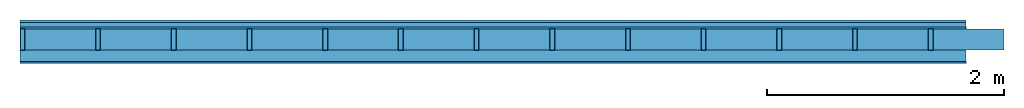
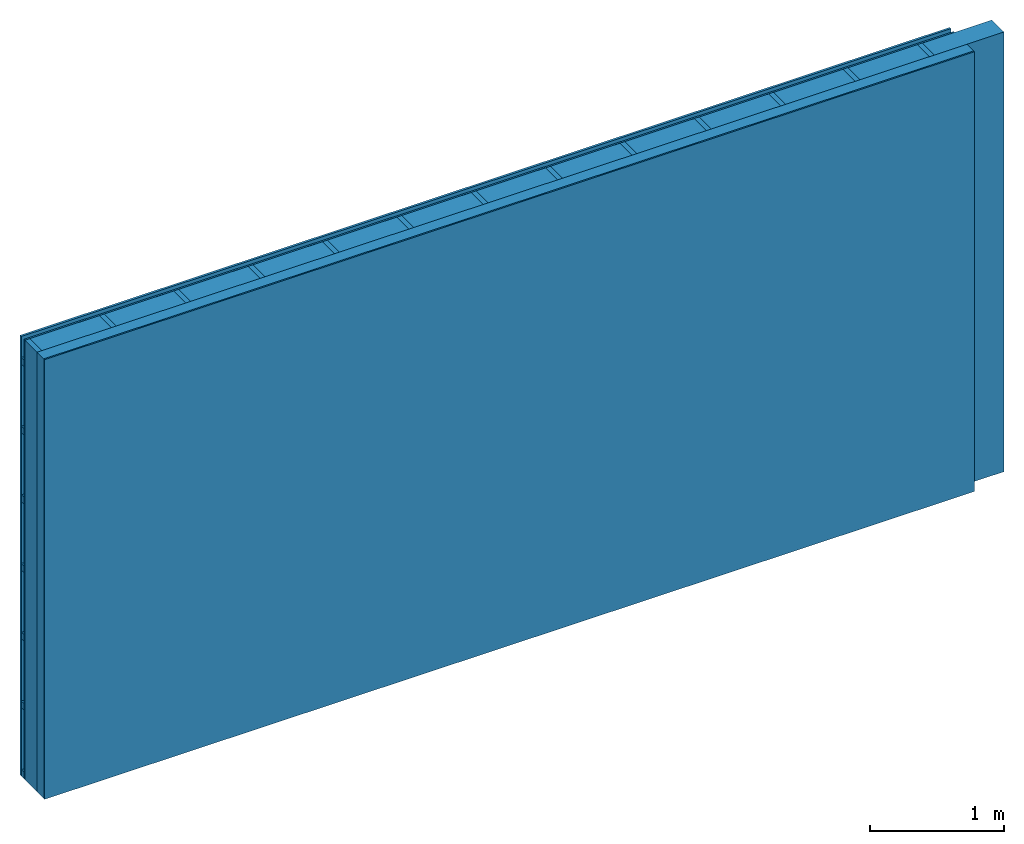
# One storey: 4 plates, 3 members, 1 element without a shape of its own.
"""IFC4 building model written with IfcOpenShell, lengths in metres."""

import ifcopenshell
import ifcopenshell.guid

model = None  # the IFC model being written
_history = None  # IfcOwnerHistory: only IFC2X3 demands one
_inside = {}  # id of a spatial element -> (the spatial element, [elements in it])
_under = {}  # id of a project, library or spatial element -> (it, [spatial elements below it])
_declared = {}  # id of a project -> (the project, [libraries it declares])
_typed = {}  # id of a type object -> (the type object, [elements of that type])
_made_of = {}  # id of a material, layer set ... -> (it, [elements and type objects made of it])


def new_model(schema):
    """Start an empty IFC model of exactly this schema.

    Asked for "IFC4X3", IfcOpenShell would pick the latest addendum, in which some entities
    have other attributes; the version numbers below select the first issue.
    IFC2X3 requires an IfcOwnerHistory on every rooted entity: one is made here for all.
    """
    global model, _history
    if schema == "IFC4X3":
        model = ifcopenshell.file(schema_version=(4, 3, 0, 0))
    else:
        model = ifcopenshell.file(schema=schema)
    _inside.clear()
    _under.clear()
    _declared.clear()
    _typed.clear()
    _made_of.clear()
    _history = None
    if model.schema == "IFC2X3":
        org = make("IfcOrganization", Name="unknown")
        user = make(
            "IfcPersonAndOrganization",
            ThePerson=make("IfcPerson", FamilyName="unknown"),
            TheOrganization=org,
        )
        app = make(
            "IfcApplication",
            ApplicationDeveloper=org,
            Version="unknown",
            ApplicationFullName="unknown",
            ApplicationIdentifier="unknown",
        )
        _history = make(
            "IfcOwnerHistory",
            OwningUser=user,
            OwningApplication=app,
            ChangeAction="ADDED",
            CreationDate=0,
        )
    return model


def make(cls, **values):
    """One entity of the class cls with the attributes given. An attribute that is None is left unset."""
    return model.create_entity(
        cls, **{name: value for name, value in values.items() if value is not None}
    )


def rooted(cls, **values):
    """An entity with a GlobalId (a new one), such as an element, a storey or a relation."""
    return make(cls, GlobalId=ifcopenshell.guid.new(), OwnerHistory=_history, **values)


def si_unit(unit_type, name, prefix=None):
    """IfcSIUnit, for example si_unit("LENGTHUNIT", "METRE", prefix="MILLI")."""
    return make("IfcSIUnit", UnitType=unit_type, Prefix=prefix, Name=name)


def derived_unit(unit_type, elements):
    """IfcDerivedUnit: a product of units, each with its exponent."""
    return make(
        "IfcDerivedUnit",
        Elements=[
            make("IfcDerivedUnitElement", Unit=unit, Exponent=power)
            for unit, power in elements
        ],
        UnitType=unit_type,
    )


def assignment(units):
    """IfcUnitAssignment: the units of a project."""
    return None if units is None else make("IfcUnitAssignment", Units=units)


def point(xyz):
    """IfcCartesianPoint."""
    return None if xyz is None else make("IfcCartesianPoint", Coordinates=xyz)


def direction(xyz):
    """IfcDirection."""
    return None if xyz is None else make("IfcDirection", DirectionRatios=xyz)


def frame(location, z_axis=None, x_axis=None):
    """IfcAxis2Placement3D, a coordinate frame: its origin and axes. An axis left out is left unset."""
    return make(
        "IfcAxis2Placement3D",
        Location=point(location),
        Axis=direction(z_axis),
        RefDirection=direction(x_axis),
    )


def frame_2d(location, x_axis=None):
    """IfcAxis2Placement2D, a coordinate frame in the plane: its origin and x axis."""
    return make(
        "IfcAxis2Placement2D", Location=point(location), RefDirection=direction(x_axis)
    )


def origin():
    """The frame at (0, 0, 0) with its axes left unset."""
    return frame((0.0, 0.0, 0.0))


def origin_with_axes():
    """The frame at (0, 0, 0) with the z axis (0, 0, 1) and the x axis (1, 0, 0) written out."""
    return frame((0.0, 0.0, 0.0), z_axis=(0.0, 0.0, 1.0), x_axis=(1.0, 0.0, 0.0))


def place(relative_to, where):
    """IfcLocalPlacement: puts the frame where relative to a parent placement (None: the world)."""
    return make(
        "IfcLocalPlacement", PlacementRelTo=relative_to, RelativePlacement=where
    )


def context(
    kind, dimensions, precision=None, world=None, true_north=None, identifier=None
):
    """IfcGeometricRepresentationContext, for example the 3D "Model" context."""
    return make(
        "IfcGeometricRepresentationContext",
        ContextIdentifier=identifier,
        ContextType=kind,
        CoordinateSpaceDimension=dimensions,
        Precision=precision,
        WorldCoordinateSystem=world,
        TrueNorth=true_north,
    )


def project(units=None, contexts=None):
    """IfcProject with its units and contexts."""
    return rooted(
        "IfcProject",
        Name="project",
        RepresentationContexts=contexts,
        UnitsInContext=assignment(units),
    )


def spatial(cls, under=None, at=None, **own):
    """A site, building, storey or space (cls), placed at a placement, below another one or the project."""
    s = rooted(cls, ObjectPlacement=at, **own)
    if under is not None:
        _under.setdefault(under.id(), (under, []))[1].append(s)
    return s


def profile(cls, at=None, kind="AREA", **sizes):
    """A parametric profile (cls). Its sizes go by their IFC names, for example OverallWidth=200.0."""
    return make(cls, ProfileType=kind, Position=at, **sizes)


def rectangle(**sizes):
    """IfcRectangleProfileDef."""
    return profile("IfcRectangleProfileDef", **sizes)


def extrude(swept, where, along, depth):
    """IfcExtrudedAreaSolid: the profile swept, set in the frame where, extruded along a direction by depth."""
    return make(
        "IfcExtrudedAreaSolid",
        SweptArea=swept,
        Position=where,
        ExtrudedDirection=direction(along),
        Depth=depth,
    )


def shape(context_of_items, identifier, shape_type, items):
    """IfcShapeRepresentation: the items that make up one representation, for example the "Body"."""
    return make(
        "IfcShapeRepresentation",
        ContextOfItems=context_of_items,
        RepresentationIdentifier=identifier,
        RepresentationType=shape_type,
        Items=items,
    )


def material(Name=None, Category=None):
    """IfcMaterial."""
    return make("IfcMaterial", Name=Name, Category=Category)


def layer(
    of_material, thickness, ventilated=None, Name=None, Category=None, Priority=None
):
    """IfcMaterialLayer: one layer of a wall or slab, of a material (None: an air gap)."""
    return make(
        "IfcMaterialLayer",
        Material=of_material,
        LayerThickness=thickness,
        IsVentilated=ventilated,
        Name=Name,
        Category=Category,
        Priority=Priority,
    )


def layer_set(layers, Name=None):
    """IfcMaterialLayerSet."""
    return make("IfcMaterialLayerSet", MaterialLayers=layers, LayerSetName=Name)


def made_of(thing, what):
    """Note that an element or type object is made of a material, layer set ...; save() writes the relation."""
    if what is not None:
        _made_of.setdefault(what.id(), (what, []))[1].append(thing)
    return thing


def type_object(cls, material=None, **own):
    """A type object (cls), such as IfcWallType, which elements share."""
    return made_of(rooted(cls, **own), material)


def element(
    cls,
    number,
    at=None,
    inside=None,
    cuts=None,
    type_object=None,
    material=None,
    context=None,
    identifier="Body",
    shape_type=None,
    held_by="IfcProductDefinitionShape",
    body=None,
    shapes=None,
    **own,
):
    """One element of the class cls, such as IfcWall. Its Tag is "e" and its number.

    at: its placement. inside: the storey or other place that contains it. cuts: it is an
    opening in that element (IfcRelVoidsElement). A single representation is given by context,
    identifier, shape_type and body (its items); several are given by shapes. held_by: the class
    of the entity that holds the representations. save() writes the other relations.
    """
    e = rooted(cls, Tag="e%d" % number, ObjectPlacement=at, **own)
    if body is not None:
        shapes = [shape(context, identifier, shape_type, body)]
    if shapes is not None:
        e.Representation = make(held_by, Representations=shapes)
    if inside is not None:
        _inside.setdefault(inside.id(), (inside, []))[1].append(e)
    if cuts is not None:
        rooted(
            "IfcRelVoidsElement", RelatingBuildingElement=cuts, RelatedOpeningElement=e
        )
    if type_object is not None:
        _typed.setdefault(type_object.id(), (type_object, []))[1].append(e)
    return made_of(e, material)


def aggregate(whole, parts):
    """IfcRelAggregates: a whole, such as a stair, and the parts it consists of."""
    return rooted("IfcRelAggregates", RelatingObject=whole, RelatedObjects=parts)


def save(model, path):
    """Write the relations noted so far, then the file.

    IfcRelAggregates (storeys below a building ...), IfcRelContainedInSpatialStructure (elements
    in a storey), IfcRelDefinesByType, IfcRelAssociatesMaterial and IfcRelDeclares: one each for
    every whole, place, type object, material and project.
    """
    for whole, parts in _under.values():
        aggregate(whole, parts)
    for where, things in _inside.values():
        rooted(
            "IfcRelContainedInSpatialStructure",
            RelatedElements=things,
            RelatingStructure=where,
        )
    for kind, things in _typed.values():
        rooted("IfcRelDefinesByType", RelatedObjects=things, RelatingType=kind)
    for what, things in _made_of.values():
        rooted("IfcRelAssociatesMaterial", RelatedObjects=things, RelatingMaterial=what)
    for by, libraries in _declared.values():
        rooted("IfcRelDeclares", RelatingContext=by, RelatedDefinitions=libraries)
    model.write(path)


model = new_model("IFC4")

# Units and contexts
plan_context = context("Plan", 3, precision=1e-05, world=origin(), true_north=direction((0.0, 1.0)))
model_context = context("Model", 3, precision=1e-05, world=origin(), true_north=direction((0.0, 1.0)))
ifc_project = project(units=[si_unit("LENGTHUNIT", "METRE"), derived_unit("SOUNDPRESSUREUNIT", [(si_unit("PRESSUREUNIT", "PASCAL", prefix="MICRO"), 0)]), si_unit("ENERGYUNIT", "JOULE", prefix="MEGA"), si_unit("MASSUNIT", "GRAM", prefix="KILO"), derived_unit("THERMALTRANSMITTANCEUNIT", [(si_unit("POWERUNIT", "WATT"), 1), (si_unit("AREAUNIT", "SQUARE_METRE"), -1), (si_unit("THERMODYNAMICTEMPERATUREUNIT", "KELVIN"), -1)]), derived_unit("AREADENSITYUNIT", [(si_unit("MASSUNIT", "GRAM", prefix="KILO"), 1), (si_unit("AREAUNIT", "SQUARE_METRE"), -1)]), derived_unit("USERDEFINED", [(si_unit("ENERGYUNIT", "JOULE", prefix="MEGA"), 1), (si_unit("AREAUNIT", "SQUARE_METRE"), -1)])], contexts=[plan_context, model_context])

# Site, building, storey
site = spatial("IfcSite", under=ifc_project)
building_placement = place(None, origin())
building = spatial("IfcBuilding", under=site, at=building_placement)
storey_placement = place(building_placement, origin())
storey = spatial("IfcBuildingStorey", under=building, at=storey_placement)

# Wall, members, plates
ifc_material_1 = material(Name="Wood cladding horizontal, closed")
ifc_layer_1 = layer(ifc_material_1, 0.02, Name="Cover 1st layer")
ifc_layer_2 = layer(None, 0.04, Name="Battens / profiles (ventilation)")
ifc_material_2 = material(Category="03.007")
ifc_layer_3 = layer(ifc_material_2, 0.015, Name="outside 1st layer")
ifc_material_3 = material(Name="of the art")
ifc_layer_4 = layer(ifc_material_3, 0.0, Name="Bond")
ifc_layer_5 = layer(None, 0.18, Name="Support")
ifc_layer_6 = layer(ifc_material_3, 0.0, Name="Bond")
ifc_material_4 = material(Name="Solid timber panel")
ifc_layer_7 = layer(ifc_material_4, 0.1, Name="1st layer")
ifc_material_5 = material(Name="Plasterboard type A", Category="03.008")
ifc_layer_8 = layer(ifc_material_5, 0.0125, Name="Covering 1st layer")
ifc_material_6 = material(Name="joints", Category="04.017")
ifc_layer_9 = layer(ifc_material_6, 0.0, Name="Surface")
ifc_layer_set = layer_set([ifc_layer_1, ifc_layer_2, ifc_layer_3, ifc_layer_4, ifc_layer_5, ifc_layer_6, ifc_layer_7, ifc_layer_8, ifc_layer_9])
wall_type = type_object("IfcWallType", Name="D0990", PredefinedType="NOTDEFINED", material=ifc_layer_set)
wall_placement = place(None, frame((0.0, 0.0, 0.0), z_axis=(0.0, -1.0, 0.0), x_axis=(1.0, 0.0, 0.0)))
wall = element("IfcWall", 1, at=wall_placement, inside=storey, type_object=wall_type, material=ifc_layer_set, Name="Wall #1")
ifc_material_7 = material()
member_1_placement = place(wall_placement, origin())
member_1 = element("IfcMember", 2, at=member_1_placement, material=ifc_material_7, Name="Battens / profiles (ventilation)", context=plan_context, shape_type="SweptSolid", body=[
    extrude(rectangle(XDim=0.06, YDim=0.04, at=frame_2d((0.03, 0.02), x_axis=(1.0, 0.0))), frame((0.0, 0.0, 0.02), z_axis=(1.0, 0.0, 0.0), x_axis=(0.0, 1.0, 0.0)), (0.0, 0.0, 1.0), 8.0),
    extrude(rectangle(XDim=0.06, YDim=0.04, at=frame_2d((0.03, 0.02), x_axis=(1.0, 0.0))), frame((0.0, 0.625, 0.02), z_axis=(1.0, 0.0, 0.0), x_axis=(0.0, 1.0, 0.0)), (0.0, 0.0, 1.0), 8.0),
    extrude(rectangle(XDim=0.06, YDim=0.04, at=frame_2d((0.03, 0.02), x_axis=(1.0, 0.0))), frame((0.0, 1.25, 0.02), z_axis=(1.0, 0.0, 0.0), x_axis=(0.0, 1.0, 0.0)), (0.0, 0.0, 1.0), 8.0),
    extrude(rectangle(XDim=0.06, YDim=0.04, at=frame_2d((0.03, 0.02), x_axis=(1.0, 0.0))), frame((0.0, 1.875, 0.02), z_axis=(1.0, 0.0, 0.0), x_axis=(0.0, 1.0, 0.0)), (0.0, 0.0, 1.0), 8.0),
    extrude(rectangle(XDim=0.06, YDim=0.04, at=frame_2d((0.03, 0.02), x_axis=(1.0, 0.0))), frame((0.0, 2.5, 0.02), z_axis=(1.0, 0.0, 0.0), x_axis=(0.0, 1.0, 0.0)), (0.0, 0.0, 1.0), 8.0),
    extrude(rectangle(XDim=0.06, YDim=0.04, at=frame_2d((0.03, 0.02), x_axis=(1.0, 0.0))), frame((0.0, 3.125, 0.02), z_axis=(1.0, 0.0, 0.0), x_axis=(0.0, 1.0, 0.0)), (0.0, 0.0, 1.0), 8.0),
    extrude(rectangle(XDim=0.06, YDim=0.04, at=frame_2d((0.03, 0.02), x_axis=(1.0, 0.0))), frame((0.0, 3.75, 0.02), z_axis=(1.0, 0.0, 0.0), x_axis=(0.0, 1.0, 0.0)), (0.0, 0.0, 1.0), 8.0),
])
ifc_material_8 = material()
member_2_placement = place(wall_placement, origin())
member_2 = element("IfcMember", 3, at=member_2_placement, material=ifc_material_8, Name="Support", context=plan_context, shape_type="SweptSolid", body=[
    extrude(rectangle(XDim=0.04, YDim=0.18, at=frame_2d((0.02, 0.09), x_axis=(1.0, 0.0))), frame((0.0, 4.0, 0.075), z_axis=(0.0, -1.0, 0.0), x_axis=(1.0, 0.0, 0.0)), (0.0, 0.0, 1.0), 4.0),
    extrude(rectangle(XDim=0.04, YDim=0.18, at=frame_2d((0.02, 0.09), x_axis=(1.0, 0.0))), frame((0.64, 4.0, 0.075), z_axis=(0.0, -1.0, 0.0), x_axis=(1.0, 0.0, 0.0)), (0.0, 0.0, 1.0), 4.0),
    extrude(rectangle(XDim=0.04, YDim=0.18, at=frame_2d((0.02, 0.09), x_axis=(1.0, 0.0))), frame((1.28, 4.0, 0.075), z_axis=(0.0, -1.0, 0.0), x_axis=(1.0, 0.0, 0.0)), (0.0, 0.0, 1.0), 4.0),
    extrude(rectangle(XDim=0.04, YDim=0.18, at=frame_2d((0.02, 0.09), x_axis=(1.0, 0.0))), frame((1.92, 4.0, 0.075), z_axis=(0.0, -1.0, 0.0), x_axis=(1.0, 0.0, 0.0)), (0.0, 0.0, 1.0), 4.0),
    extrude(rectangle(XDim=0.04, YDim=0.18, at=frame_2d((0.02, 0.09), x_axis=(1.0, 0.0))), frame((2.56, 4.0, 0.075), z_axis=(0.0, -1.0, 0.0), x_axis=(1.0, 0.0, 0.0)), (0.0, 0.0, 1.0), 4.0),
    extrude(rectangle(XDim=0.04, YDim=0.18, at=frame_2d((0.02, 0.09), x_axis=(1.0, 0.0))), frame((3.2, 4.0, 0.075), z_axis=(0.0, -1.0, 0.0), x_axis=(1.0, 0.0, 0.0)), (0.0, 0.0, 1.0), 4.0),
    extrude(rectangle(XDim=0.04, YDim=0.18, at=frame_2d((0.02, 0.09), x_axis=(1.0, 0.0))), frame((3.84, 4.0, 0.075), z_axis=(0.0, -1.0, 0.0), x_axis=(1.0, 0.0, 0.0)), (0.0, 0.0, 1.0), 4.0),
    extrude(rectangle(XDim=0.04, YDim=0.18, at=frame_2d((0.02, 0.09), x_axis=(1.0, 0.0))), frame((4.48, 4.0, 0.075), z_axis=(0.0, -1.0, 0.0), x_axis=(1.0, 0.0, 0.0)), (0.0, 0.0, 1.0), 4.0),
    extrude(rectangle(XDim=0.04, YDim=0.18, at=frame_2d((0.02, 0.09), x_axis=(1.0, 0.0))), frame((5.12, 4.0, 0.075), z_axis=(0.0, -1.0, 0.0), x_axis=(1.0, 0.0, 0.0)), (0.0, 0.0, 1.0), 4.0),
    extrude(rectangle(XDim=0.04, YDim=0.18, at=frame_2d((0.02, 0.09), x_axis=(1.0, 0.0))), frame((5.76, 4.0, 0.075), z_axis=(0.0, -1.0, 0.0), x_axis=(1.0, 0.0, 0.0)), (0.0, 0.0, 1.0), 4.0),
    extrude(rectangle(XDim=0.04, YDim=0.18, at=frame_2d((0.02, 0.09), x_axis=(1.0, 0.0))), frame((6.4, 4.0, 0.075), z_axis=(0.0, -1.0, 0.0), x_axis=(1.0, 0.0, 0.0)), (0.0, 0.0, 1.0), 4.0),
    extrude(rectangle(XDim=0.04, YDim=0.18, at=frame_2d((0.02, 0.09), x_axis=(1.0, 0.0))), frame((7.04, 4.0, 0.075), z_axis=(0.0, -1.0, 0.0), x_axis=(1.0, 0.0, 0.0)), (0.0, 0.0, 1.0), 4.0),
    extrude(rectangle(XDim=0.04, YDim=0.18, at=frame_2d((0.02, 0.09), x_axis=(1.0, 0.0))), frame((7.68, 4.0, 0.075), z_axis=(0.0, -1.0, 0.0), x_axis=(1.0, 0.0, 0.0)), (0.0, 0.0, 1.0), 4.0),
])
ifc_material_9 = material(Name="Mineral wool")
member_3_placement = place(wall_placement, origin())
member_3 = element("IfcMember", 4, at=member_3_placement, material=ifc_material_9, Name="Cavity", context=plan_context, shape_type="SweptSolid", body=[
    extrude(rectangle(XDim=0.6, YDim=0.18, at=frame_2d((0.3, 0.09), x_axis=(1.0, 0.0))), frame((0.04, 4.0, 0.075), z_axis=(0.0, -1.0, 0.0), x_axis=(1.0, 0.0, 0.0)), (0.0, 0.0, 1.0), 4.0),
    extrude(rectangle(XDim=0.6, YDim=0.18, at=frame_2d((0.3, 0.09), x_axis=(1.0, 0.0))), frame((0.68, 4.0, 0.075), z_axis=(0.0, -1.0, 0.0), x_axis=(1.0, 0.0, 0.0)), (0.0, 0.0, 1.0), 4.0),
    extrude(rectangle(XDim=0.6, YDim=0.18, at=frame_2d((0.3, 0.09), x_axis=(1.0, 0.0))), frame((1.32, 4.0, 0.075), z_axis=(0.0, -1.0, 0.0), x_axis=(1.0, 0.0, 0.0)), (0.0, 0.0, 1.0), 4.0),
    extrude(rectangle(XDim=0.6, YDim=0.18, at=frame_2d((0.3, 0.09), x_axis=(1.0, 0.0))), frame((1.96, 4.0, 0.075), z_axis=(0.0, -1.0, 0.0), x_axis=(1.0, 0.0, 0.0)), (0.0, 0.0, 1.0), 4.0),
    extrude(rectangle(XDim=0.6, YDim=0.18, at=frame_2d((0.3, 0.09), x_axis=(1.0, 0.0))), frame((2.6, 4.0, 0.075), z_axis=(0.0, -1.0, 0.0), x_axis=(1.0, 0.0, 0.0)), (0.0, 0.0, 1.0), 4.0),
    extrude(rectangle(XDim=0.6, YDim=0.18, at=frame_2d((0.3, 0.09), x_axis=(1.0, 0.0))), frame((3.24, 4.0, 0.075), z_axis=(0.0, -1.0, 0.0), x_axis=(1.0, 0.0, 0.0)), (0.0, 0.0, 1.0), 4.0),
    extrude(rectangle(XDim=0.6, YDim=0.18, at=frame_2d((0.3, 0.09), x_axis=(1.0, 0.0))), frame((3.88, 4.0, 0.075), z_axis=(0.0, -1.0, 0.0), x_axis=(1.0, 0.0, 0.0)), (0.0, 0.0, 1.0), 4.0),
    extrude(rectangle(XDim=0.6, YDim=0.18, at=frame_2d((0.3, 0.09), x_axis=(1.0, 0.0))), frame((4.52, 4.0, 0.075), z_axis=(0.0, -1.0, 0.0), x_axis=(1.0, 0.0, 0.0)), (0.0, 0.0, 1.0), 4.0),
    extrude(rectangle(XDim=0.6, YDim=0.18, at=frame_2d((0.3, 0.09), x_axis=(1.0, 0.0))), frame((5.16, 4.0, 0.075), z_axis=(0.0, -1.0, 0.0), x_axis=(1.0, 0.0, 0.0)), (0.0, 0.0, 1.0), 4.0),
    extrude(rectangle(XDim=0.6, YDim=0.18, at=frame_2d((0.3, 0.09), x_axis=(1.0, 0.0))), frame((5.8, 4.0, 0.075), z_axis=(0.0, -1.0, 0.0), x_axis=(1.0, 0.0, 0.0)), (0.0, 0.0, 1.0), 4.0),
    extrude(rectangle(XDim=0.6, YDim=0.18, at=frame_2d((0.3, 0.09), x_axis=(1.0, 0.0))), frame((6.44, 4.0, 0.075), z_axis=(0.0, -1.0, 0.0), x_axis=(1.0, 0.0, 0.0)), (0.0, 0.0, 1.0), 4.0),
    extrude(rectangle(XDim=0.6, YDim=0.18, at=frame_2d((0.3, 0.09), x_axis=(1.0, 0.0))), frame((7.08, 4.0, 0.075), z_axis=(0.0, -1.0, 0.0), x_axis=(1.0, 0.0, 0.0)), (0.0, 0.0, 1.0), 4.0),
    extrude(rectangle(XDim=0.6, YDim=0.18, at=frame_2d((0.3, 0.09), x_axis=(1.0, 0.0))), frame((7.72, 4.0, 0.075), z_axis=(0.0, -1.0, 0.0), x_axis=(1.0, 0.0, 0.0)), (0.0, 0.0, 1.0), 4.0),
])
plate_1_placement = place(wall_placement, origin())
plate_1 = element("IfcPlate", 5, at=plate_1_placement, material=ifc_material_1, Name="Cover 1st layer", context=plan_context, shape_type="SweptSolid", body=[
    extrude(rectangle(XDim=8.0, YDim=4.0, at=frame_2d((4.0, 2.0), x_axis=(1.0, 0.0))), origin_with_axes(), (0.0, 0.0, 1.0), 0.02),
])
plate_2_placement = place(wall_placement, origin())
plate_2 = element("IfcPlate", 6, at=plate_2_placement, material=ifc_material_2, Name="outside 1st layer", context=plan_context, shape_type="SweptSolid", body=[
    extrude(rectangle(XDim=8.0, YDim=4.0, at=frame_2d((4.0, 2.0), x_axis=(1.0, 0.0))), frame((0.0, 0.0, 0.06), z_axis=(0.0, 0.0, 1.0), x_axis=(1.0, 0.0, 0.0)), (0.0, 0.0, 1.0), 0.015),
])
plate_3_placement = place(wall_placement, origin())
plate_3 = element("IfcPlate", 7, at=plate_3_placement, material=ifc_material_4, Name="1st layer", context=plan_context, shape_type="SweptSolid", body=[
    extrude(rectangle(XDim=8.0, YDim=4.0, at=frame_2d((4.0, 2.0), x_axis=(1.0, 0.0))), frame((0.0, 0.0, 0.255), z_axis=(0.0, 0.0, 1.0), x_axis=(1.0, 0.0, 0.0)), (0.0, 0.0, 1.0), 0.1),
])
plate_4_placement = place(wall_placement, origin())
plate_4 = element("IfcPlate", 8, at=plate_4_placement, material=ifc_material_5, Name="Covering 1st layer", context=plan_context, shape_type="SweptSolid", body=[
    extrude(rectangle(XDim=8.0, YDim=4.0, at=frame_2d((4.0, 2.0), x_axis=(1.0, 0.0))), frame((0.0, 0.0, 0.355), z_axis=(0.0, 0.0, 1.0), x_axis=(1.0, 0.0, 0.0)), (0.0, 0.0, 1.0), 0.0125),
])
aggregate(wall, [plate_1, member_1, plate_2, member_2, member_3, plate_3, plate_4])

save(model, "model.ifc")
